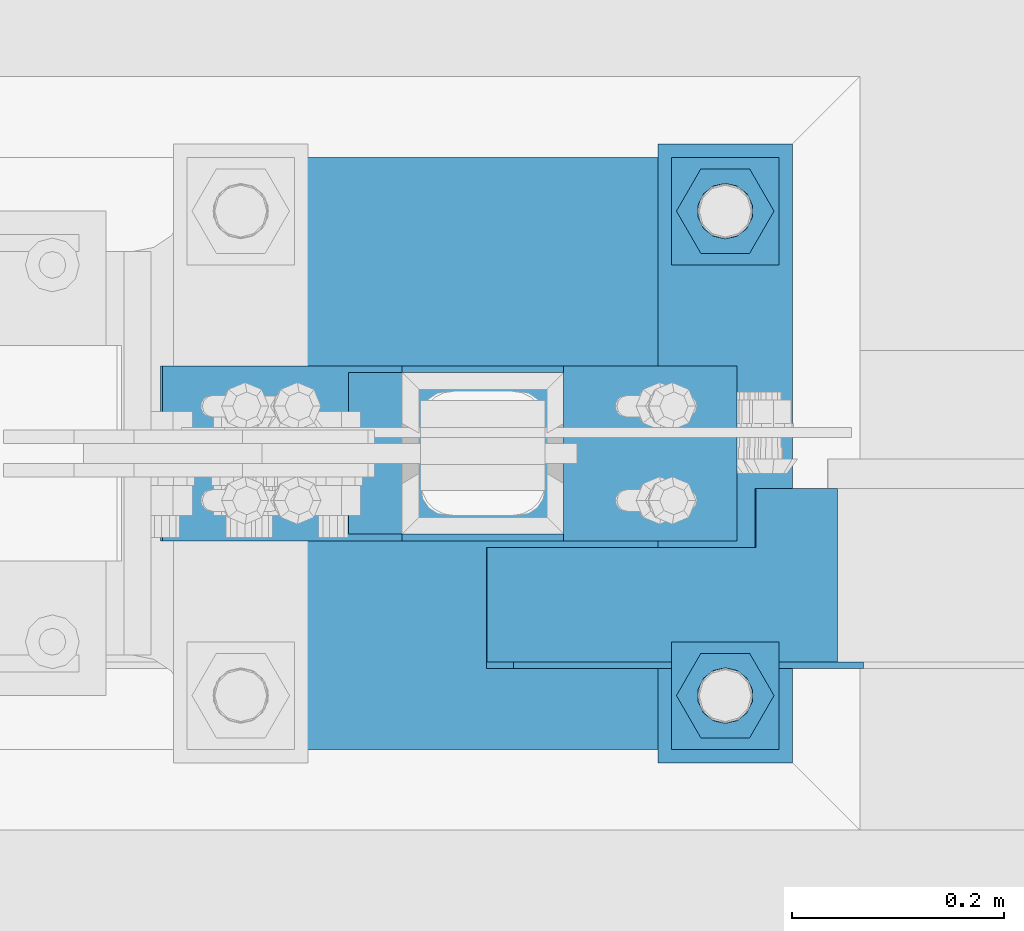
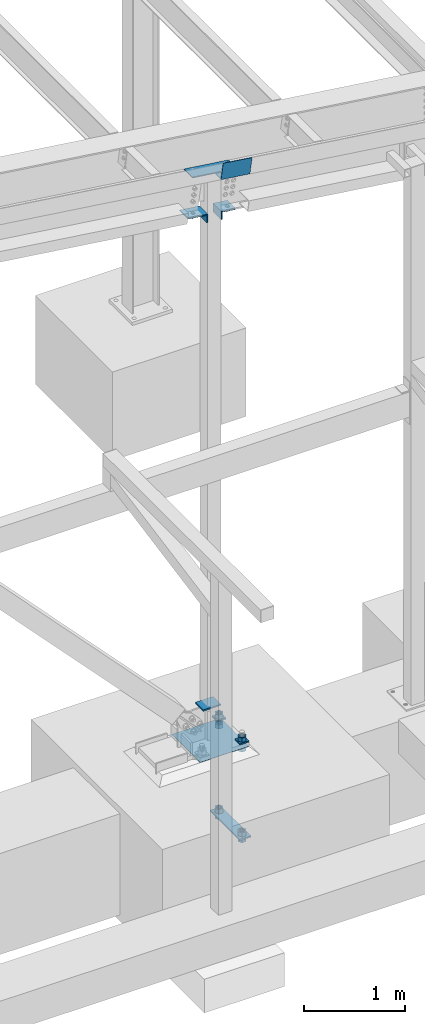
# One storey, part 853 of 1179: 17 beams, 3 elements without a shape of their own.
"""IFC2X3 building model written with IfcOpenShell, lengths in millimetres."""

from ifc_helpers import new_model, si_unit, frame, origin_with_axes, place, context, subcontext, project, spatial, faceted_brep, material, type_object, element, aggregate, save


model = new_model("IFC2X3")

# Units and contexts
model_context = context("Model", 3, precision=1e-05, world=origin_with_axes())
body_context = subcontext(model_context, "Body", "Model", "MODEL_VIEW")
ifc_project = project(units=[si_unit("LENGTHUNIT", "METRE", prefix="MILLI"), si_unit("AREAUNIT", "SQUARE_METRE"), si_unit("VOLUMEUNIT", "CUBIC_METRE"), si_unit("MASSUNIT", "GRAM", prefix="KILO"), si_unit("TIMEUNIT", "SECOND"), si_unit("PLANEANGLEUNIT", "RADIAN"), si_unit("SOLIDANGLEUNIT", "STERADIAN"), si_unit("THERMODYNAMICTEMPERATUREUNIT", "DEGREE_CELSIUS"), si_unit("LUMINOUSINTENSITYUNIT", "LUMEN")], contexts=[model_context])

# Site, building, storey
site_placement = place(None, origin_with_axes())
site = spatial("IfcSite", under=ifc_project, at=site_placement, CompositionType="ELEMENT")
building_placement = place(site_placement, origin_with_axes())
building = spatial("IfcBuilding", under=site, at=building_placement, Name="Undefined", CompositionType="ELEMENT")
storey_placement = place(building_placement, origin_with_axes())
storey = spatial("IfcBuildingStorey", under=building, at=storey_placement, Name="Undefined", CompositionType="ELEMENT", Elevation=0.0)

# Assembly, beam
assembly_1_placement = place(storey_placement, origin_with_axes())
assembly_1 = element("IfcElementAssembly", 1, at=assembly_1_placement, inside=storey, Name="TEMPLATE", AssemblyPlace="NOTDEFINED", PredefinedType="RIGID_FRAME")
ifc_material = material(Name="STEEL/A36")
beam_type_1 = type_object("IfcBeamType", PredefinedType="NOTDEFINED")
beam_1_placement = place(assembly_1_placement, frame((35153.6000061035, 4356.09999389649, -1362.075), z_axis=(-1.0, 0.0, 0.0), x_axis=(0.0, 1.0, 0.0)))
beam_1 = element("IfcBeam", 2, at=beam_1_placement, type_object=beam_type_1, material=ifc_material, Name="SQ WASHER", context=body_context, shape_type="Brep", body=[
    faceted_brep([(0.0, 9.52500000000146, -63.5), (0.0, 9.52500000000146, 63.5), (584.199999999997, 9.52500000000009, 63.5), (584.199999999997, 9.52500000000009, -63.5), (0.0, -9.52500000000146, 63.5), (584.199999999997, -9.52500000000009, 63.5), (0.0, -9.52500000000146, -63.5), (584.199999999997, -9.52500000000009, -63.5)], [[[0, 1, 2, 3]], [[1, 4, 5, 2]], [[4, 6, 7, 5]], [[6, 0, 3, 7]], [[5, 7, 3, 2]], [[6, 4, 1, 0]]]),
])

assembly_2_placement = place(storey_placement, origin_with_axes())
assembly_2 = element("IfcElementAssembly", 3, at=assembly_2_placement, inside=storey, Name="BEAM", AssemblyPlace="NOTDEFINED", PredefinedType="RIGID_FRAME")
beam_type_2 = type_object("IfcBeamType", PredefinedType="NOTDEFINED")
beam_2_placement = place(assembly_2_placement, frame((35118.8262726034, 4448.17500002817, 6769.07814906034), z_axis=(0.99100656965293, 0.0, -0.133813223953134), x_axis=(-0.133813222971046, 0.0, -0.991006569785539)))
beam_2 = element("IfcBeam", 4, at=beam_2_placement, type_object=beam_type_2, material=ifc_material, Name="BENT_PLATE", context=body_context, shape_type="Brep", body=[
    faceted_brep([(190.500000000864, 111.125000986845, 89.1470595671053), (184.150000000862, 111.125000986845, 89.1470595671271), (184.15000000084, 166.687499975929, 89.1470595669234), (190.500000000842, 166.687499975929, 89.1470595669234), (190.500000000628, 111.125000986845, -166.6875000004), (184.150000000625, 111.125000986845, -166.687500000393), (-1.21872290037572e-10, 3.17500000000018, -166.687500000036), (1.20053300634027e-10, 3.17500000000018, 166.687500000036), (184.15000000098, 3.17500000000018, 166.687499999738), (184.150000000571, 3.17500000000018, -166.687500000342), (-1.21872290037572e-10, -3.17500000000018, -166.687500000036), (1.20053300634027e-10, -3.17500000000018, 166.687500000036), (190.500000000573, -3.17500000000018, -166.687500000342), (190.500000000982, -3.17500000000018, 166.687499999724), (190.5000000009, 166.687499975969, 166.687499999643), (184.150000000898, 166.687499975969, 166.687499999651)], [[[0, 1, 2, 3]], [[4, 5, 1, 0]], [[6, 7, 8, 9]], [[10, 11, 7, 6]], [[11, 10, 12, 13]], [[8, 7, 11, 13, 14, 15]], [[15, 14, 3, 2]], [[9, 8, 15, 2, 1, 5]], [[12, 10, 6, 9, 5, 4]], [[14, 13, 12, 4, 0, 3]]]),
])
aggregate(assembly_2, [beam_2])

# Assembly, beams
assembly_3_placement = place(storey_placement, origin_with_axes())
assembly_3 = element("IfcElementAssembly", 5, at=assembly_3_placement, inside=storey, Name="COLUMN", AssemblyPlace="NOTDEFINED", PredefinedType="RIGID_FRAME")
beam_type_3 = type_object("IfcBeamType", PredefinedType="NOTDEFINED")
beam_3_placement = place(assembly_3_placement, frame((35007.55, 4648.2000010376, 6020.17159338622), z_axis=(0.0, -1.0, 0.0), x_axis=(0.0, 0.0, 1.0)))
beam_3 = element("IfcBeam", 6, at=beam_3_placement, type_object=beam_type_3, material=ifc_material, Name="BENT_PLATE", context=body_context, shape_type="Brep", body=[
    faceted_brep([(-7.27595761418343e-12, -6.35000000000218, -82.5500000000002), (-7.27595761418343e-12, -6.35000000000218, 82.5500000000002), (1.09139364212751e-11, 6.35000000000218, 82.5500000000002), (1.09139364212751e-11, 6.35000000000218, -82.5500000000002), (101.6, 6.34999999999854, 82.5500000000002), (101.6, 6.34999999999854, -82.5500000000002), (87.0698965827769, -6.34999999999854, -82.5500000000002), (87.0698965827769, -6.34999999999854, 82.5500000000002), (79.5197174631803, -157.174234805418, 82.5500000000002), (79.5197174631803, -157.174234805418, -82.5500000000002), (66.9339340285887, -155.474806861217, 82.5500000000002), (66.9339340285887, -155.474806861217, -82.5500000000002)], [[[0, 1, 2, 3]], [[3, 2, 4, 5]], [[1, 0, 6, 7]], [[5, 4, 8, 9]], [[4, 2, 1, 7, 10, 8]], [[7, 6, 11, 10]], [[6, 0, 3, 5, 9, 11]], [[10, 11, 9, 8]]]),
])
beam_4_placement = place(assembly_3_placement, frame((34621.591346649, 4648.2000010376, 6166.62160660569), z_axis=(0.0, -1.0, 0.0), x_axis=(0.99100656965293, 0.0, -0.133813223953134)))
beam_4 = element("IfcBeam", 7, at=beam_4_placement, type_object=beam_type_3, material=ifc_material, Name="BENT_PLATE", context=body_context, shape_type="Brep", body=[
    faceted_brep([(-7.27595761418343e-12, -6.35000000000218, -82.5500000000002), (-7.27595761418343e-12, -6.35000000000218, 82.5500000000002), (1.09139364212751e-11, 6.35000000000218, 82.5500000000002), (1.09139364212751e-11, 6.35000000000218, -82.5500000000002), (228.413157209885, 6.35000000041691, 82.5500000000002), (228.413157209885, 6.35000000041691, -82.5500000000002), (217.312754455081, -6.34999999960746, -82.5500000000002), (217.312754455081, -6.34999999960746, 82.5500000000002), (242.008580763424, -94.3362674762175, 82.5500000000002), (242.008580763424, -94.3362674762175, -82.5500000000002), (229.422797328829, -96.0356954204253, 82.5500000000002), (229.422797328829, -96.0356954204253, -82.5500000000002)], [[[0, 1, 2, 3]], [[3, 2, 4, 5]], [[1, 0, 6, 7]], [[5, 4, 8, 9]], [[4, 2, 1, 7, 10, 8]], [[7, 6, 11, 10]], [[6, 0, 3, 5, 9, 11]], [[10, 11, 9, 8]]]),
])
beam_5_placement = place(assembly_3_placement, frame((34673.4487458878, 4648.2000010376, 6643.39523121626), z_axis=(0.0, -1.0, 0.0), x_axis=(0.99100656965293, 0.0, -0.133813223953134)))
beam_5 = element("IfcBeam", 8, at=beam_5_placement, type_object=beam_type_3, material=ifc_material, Name="PLATE", context=body_context, shape_type="Brep", body=[
    faceted_brep([(1.09139364212751e-11, 6.35000000000218, -82.5500000000002), (1.09139364212751e-11, 6.35000000000218, 82.5500000000002), (509.383037032239, 6.34999999986394, 82.5500000000002), (509.383037032239, 6.34999999986394, -82.5500000000002), (-7.27595761418343e-12, -6.35000000000218, 82.5500000000002), (509.383037032225, -6.35000000014043, 82.5500000000002), (-7.27595761418343e-12, -6.35000000000218, -82.5500000000002), (509.383037032225, -6.35000000014043, -82.5500000000002)], [[[0, 1, 2, 3]], [[1, 4, 5, 2]], [[4, 6, 7, 5]], [[6, 0, 3, 7]], [[5, 7, 3, 2]], [[6, 4, 1, 0]]]),
])

# Beam
beam_type_4 = type_object("IfcBeamType", PredefinedType="NOTDEFINED")
beam_6_placement = place(assembly_1_placement, frame((35102.8010061035, 4419.59999389649, -220.662499999998), z_axis=(0.0, 1.0, 0.0), x_axis=(1.0, 0.0, 0.0)))
beam_6 = element("IfcBeam", 9, at=beam_6_placement, type_object=beam_type_4, material=ifc_material, Name="SQ WASHER", context=body_context, shape_type="Brep", body=[
    faceted_brep([(0.0, 7.9375, -50.8000000000002), (0.0, 7.9375, 50.8000000000002), (101.598992919513, 7.9375, 50.8000000000002), (101.598992919513, 7.9375, -50.8000000000002), (0.0, -7.9375, 50.8000000000002), (101.598992919513, -7.9375, 50.8000000000002), (0.0, -7.9375, -50.8000000000002), (101.598992919513, -7.9375, -50.8000000000002)], [[[0, 1, 2, 3]], [[1, 4, 5, 2]], [[4, 6, 7, 5]], [[6, 0, 3, 7]], [[5, 7, 3, 2]], [[6, 4, 1, 0]]]),
])

beam_7_placement = place(assembly_1_placement, frame((35102.8010061035, 4876.79999389648, -220.662499999998), z_axis=(0.0, 1.0, 0.0), x_axis=(1.0, 0.0, 0.0)))
beam_7 = element("IfcBeam", 10, at=beam_7_placement, type_object=beam_type_4, material=ifc_material, Name="SQ WASHER", context=body_context, shape_type="Brep", body=[
    faceted_brep([(0.0, 7.9375, -50.8000000000002), (0.0, 7.9375, 50.8000000000002), (101.598992919513, 7.9375, 50.8000000000002), (101.598992919513, 7.9375, -50.8000000000002), (0.0, -7.9375, 50.8000000000002), (101.598992919513, -7.9375, 50.8000000000002), (0.0, -7.9375, -50.8000000000002), (101.598992919513, -7.9375, -50.8000000000002)], [[[0, 1, 2, 3]], [[1, 4, 5, 2]], [[4, 6, 7, 5]], [[6, 0, 3, 7]], [[5, 7, 3, 2]], [[6, 4, 1, 0]]]),
])

beam_type_5 = type_object("IfcBeamType", PredefinedType="NOTDEFINED")
beam_8_placement = place(assembly_3_placement, frame((34798.0000013588, 4648.2, 169.719733064332), z_axis=(0.0, -1.0, 0.0), x_axis=(1.0, 0.0, 0.0)))
beam_8 = element("IfcBeam", 11, at=beam_8_placement, type_object=beam_type_5, material=ifc_material, Name="PLATE", context=body_context, shape_type="Brep", body=[
    faceted_brep([(0.0, 9.52500000000009, -76.2000000000007), (0.0, 9.52500000000009, 76.2000000000007), (203.200000000004, 9.52500000000001, 76.1999999999998), (203.200000000004, 9.52500000000001, -76.1999999999998), (0.0, -9.52500000000009, 76.2000000000007), (203.200000000004, -9.52500000000001, 76.1999999999998), (0.0, -9.52500000000009, -76.2000000000007), (203.200000000004, -9.52500000000001, -76.1999999999998)], [[[0, 1, 2, 3]], [[1, 4, 5, 2]], [[4, 6, 7, 5]], [[6, 0, 3, 7]], [[5, 7, 3, 2]], [[6, 4, 1, 0]]]),
])

aggregate(assembly_3, [beam_3, beam_4, beam_5, beam_8])

beam_type_6 = type_object("IfcBeamType", Name="2_HEAVY_HEX_NUT", PredefinedType="NOTDEFINED")
beam_9_placement = place(assembly_1_placement, frame((35153.600012207, 4876.8, -279.4), z_axis=(0.0, 1.0, 0.0), x_axis=(0.0, 0.0, -1.0)))
beam_9 = element("IfcBeam", 12, at=beam_9_placement, type_object=beam_type_6, material=ifc_material, Name="NUT", ObjectType="2_HEAVY_HEX_NUT", context=body_context, shape_type="Brep", body=[
    faceted_brep([(0.0, -46.0369987487793, 9.09494701772928e-13), (0.0, -23.0184993743896, -39.869213104248), (50.7999999999993, -23.0184993743896, -39.869213104248), (50.7999999999993, -46.0369987487793, 9.09494701772928e-13), (0.0, 23.0184993743896, -39.869213104248), (50.7999999999993, 23.0184993743896, -39.869213104248), (0.0, 46.0369987487793, -9.09494701772928e-13), (50.7999999999993, 46.0369987487793, -9.09494701772928e-13), (0.0, 23.0184993743896, 39.869213104248), (50.7999999999993, 23.0184993743896, 39.869213104248), (0.0, -23.0184993743896, 39.869213104248), (50.7999999999993, -23.0184993743896, 39.869213104248), (0.0, 0.0, 26.1940002441406), (0.0, 11.3650617044477, 23.5999013092769), (50.7999999999993, 11.3650617044477, 23.5999013092769), (50.7999999999993, 0.0, 26.1940002441406), (0.0, 20.4791109456419, 16.3316083006703), (50.7999999999993, 20.4791109456419, 16.3316083006703), (0.0, 25.5370200498364, 5.82867859874477), (50.7999999999993, 25.5370200498364, 5.82867859874477), (0.0, 25.5370200498364, -5.82867859874477), (50.7999999999993, 25.5370200498364, -5.82867859874477), (0.0, 20.4791109456419, -16.3316083006703), (50.7999999999993, 20.4791109456419, -16.3316083006703), (0.0, 11.365061704455, -23.5999013092769), (50.7999999999993, 11.365061704455, -23.5999013092769), (0.0, 0.0, -26.1940002441406), (50.7999999999993, 0.0, -26.1940002441406), (0.0, -11.3650617044477, -23.5999013092769), (50.7999999999993, -11.3650617044477, -23.5999013092769), (0.0, -20.4791109456419, -16.3316083006703), (50.7999999999993, -20.4791109456419, -16.3316083006703), (0.0, -25.5370200498364, -5.82867859874477), (50.7999999999993, -25.5370200498364, -5.82867859874477), (0.0, -25.5370200498364, 5.82867859874477), (50.7999999999993, -25.5370200498364, 5.82867859874477), (0.0, -20.4791109456419, 16.3316083006703), (50.7999999999993, -20.4791109456419, 16.3316083006703), (0.0, -11.365061704455, 23.5999013092769), (50.7999999999993, -11.365061704455, 23.5999013092769)], [[[0, 1, 2, 3]], [[1, 4, 5, 2]], [[4, 6, 7, 5]], [[6, 8, 9, 7]], [[8, 10, 11, 9]], [[10, 0, 3, 11]], [[12, 13, 14, 15]], [[13, 16, 17, 14]], [[16, 18, 19, 17]], [[18, 20, 21, 19]], [[20, 22, 23, 21]], [[22, 24, 25, 23]], [[24, 26, 27, 25]], [[26, 28, 29, 27]], [[28, 30, 31, 29]], [[30, 32, 33, 31]], [[32, 34, 35, 33]], [[34, 36, 37, 35]], [[36, 38, 39, 37]], [[38, 12, 15, 39]], [[5, 7, 9, 11, 3, 2], [17, 19, 21, 23, 25, 27, 29, 31, 33, 35, 37, 39, 15, 14]], [[10, 8, 6, 4, 1, 0], [38, 36, 34, 32, 30, 28, 26, 24, 22, 20, 18, 16, 13, 12]]]),
])

beam_10_placement = place(assembly_1_placement, frame((35153.600012207, 4419.6, -279.4), z_axis=(0.0, 1.0, 0.0), x_axis=(0.0, 0.0, -1.0)))
beam_10 = element("IfcBeam", 13, at=beam_10_placement, type_object=beam_type_6, material=ifc_material, Name="NUT", ObjectType="2_HEAVY_HEX_NUT", context=body_context, shape_type="Brep", body=[
    faceted_brep([(0.0, -46.0369987487793, 9.09494701772928e-13), (0.0, -23.0184993743896, -39.869213104248), (50.7999999999993, -23.0184993743896, -39.869213104248), (50.7999999999993, -46.0369987487793, 9.09494701772928e-13), (0.0, 23.0184993743896, -39.869213104248), (50.7999999999993, 23.0184993743896, -39.869213104248), (0.0, 46.0369987487793, -9.09494701772928e-13), (50.7999999999993, 46.0369987487793, -9.09494701772928e-13), (0.0, 23.0184993743896, 39.869213104248), (50.7999999999993, 23.0184993743896, 39.869213104248), (0.0, -23.0184993743896, 39.869213104248), (50.7999999999993, -23.0184993743896, 39.869213104248), (0.0, 0.0, 26.1940002441406), (0.0, 11.3650617044477, 23.5999013092769), (50.7999999999993, 11.3650617044477, 23.5999013092769), (50.7999999999993, 0.0, 26.1940002441406), (0.0, 20.4791109456419, 16.3316083006703), (50.7999999999993, 20.4791109456419, 16.3316083006703), (0.0, 25.5370200498364, 5.82867859874477), (50.7999999999993, 25.5370200498364, 5.82867859874477), (0.0, 25.5370200498364, -5.82867859874477), (50.7999999999993, 25.5370200498364, -5.82867859874477), (0.0, 20.4791109456419, -16.3316083006703), (50.7999999999993, 20.4791109456419, -16.3316083006703), (0.0, 11.365061704455, -23.5999013092769), (50.7999999999993, 11.365061704455, -23.5999013092769), (0.0, 0.0, -26.1940002441406), (50.7999999999993, 0.0, -26.1940002441406), (0.0, -11.3650617044477, -23.5999013092769), (50.7999999999993, -11.3650617044477, -23.5999013092769), (0.0, -20.4791109456419, -16.3316083006703), (50.7999999999993, -20.4791109456419, -16.3316083006703), (0.0, -25.5370200498364, -5.82867859874477), (50.7999999999993, -25.5370200498364, -5.82867859874477), (0.0, -25.5370200498364, 5.82867859874477), (50.7999999999993, -25.5370200498364, 5.82867859874477), (0.0, -20.4791109456419, 16.3316083006703), (50.7999999999993, -20.4791109456419, 16.3316083006703), (0.0, -11.365061704455, 23.5999013092769), (50.7999999999993, -11.365061704455, 23.5999013092769)], [[[0, 1, 2, 3]], [[1, 4, 5, 2]], [[4, 6, 7, 5]], [[6, 8, 9, 7]], [[8, 10, 11, 9]], [[10, 0, 3, 11]], [[12, 13, 14, 15]], [[13, 16, 17, 14]], [[16, 18, 19, 17]], [[18, 20, 21, 19]], [[20, 22, 23, 21]], [[22, 24, 25, 23]], [[24, 26, 27, 25]], [[26, 28, 29, 27]], [[28, 30, 31, 29]], [[30, 32, 33, 31]], [[32, 34, 35, 33]], [[34, 36, 37, 35]], [[36, 38, 39, 37]], [[38, 12, 15, 39]], [[5, 7, 9, 11, 3, 2], [17, 19, 21, 23, 25, 27, 29, 31, 33, 35, 37, 39, 15, 14]], [[10, 8, 6, 4, 1, 0], [38, 36, 34, 32, 30, 28, 26, 24, 22, 20, 18, 16, 13, 12]]]),
])

beam_11_placement = place(assembly_1_placement, frame((35153.6, 4876.8, -1301.75), z_axis=(0.0, 1.0, 0.0), x_axis=(0.0, 0.0, -1.0)))
beam_11 = element("IfcBeam", 14, at=beam_11_placement, type_object=beam_type_6, material=ifc_material, Name="NUT", ObjectType="2_HEAVY_HEX_NUT", context=body_context, shape_type="Brep", body=[
    faceted_brep([(0.0, -46.0369987487793, 9.09494701772928e-13), (0.0, -23.0184993743896, -39.869213104248), (50.7999999999993, -23.0184993743896, -39.869213104248), (50.7999999999993, -46.0369987487793, 9.09494701772928e-13), (0.0, 23.0184993743896, -39.869213104248), (50.7999999999993, 23.0184993743896, -39.869213104248), (0.0, 46.0369987487793, -9.09494701772928e-13), (50.7999999999993, 46.0369987487793, -9.09494701772928e-13), (0.0, 23.0184993743896, 39.869213104248), (50.7999999999993, 23.0184993743896, 39.869213104248), (0.0, -23.0184993743896, 39.869213104248), (50.7999999999993, -23.0184993743896, 39.869213104248), (0.0, 0.0, 26.1940002441406), (0.0, 11.3650617044477, 23.5999013092769), (50.7999999999993, 11.3650617044477, 23.5999013092769), (50.7999999999993, 0.0, 26.1940002441406), (0.0, 20.4791109456419, 16.3316083006703), (50.7999999999993, 20.4791109456419, 16.3316083006703), (0.0, 25.5370200498364, 5.82867859874477), (50.7999999999993, 25.5370200498364, 5.82867859874477), (0.0, 25.5370200498364, -5.82867859874477), (50.7999999999993, 25.5370200498364, -5.82867859874477), (0.0, 20.4791109456419, -16.3316083006703), (50.7999999999993, 20.4791109456419, -16.3316083006703), (0.0, 11.365061704455, -23.5999013092769), (50.7999999999993, 11.365061704455, -23.5999013092769), (0.0, 0.0, -26.1940002441406), (50.7999999999993, 0.0, -26.1940002441406), (0.0, -11.3650617044477, -23.5999013092769), (50.7999999999993, -11.3650617044477, -23.5999013092769), (0.0, -20.4791109456419, -16.3316083006703), (50.7999999999993, -20.4791109456419, -16.3316083006703), (0.0, -25.5370200498364, -5.82867859874477), (50.7999999999993, -25.5370200498364, -5.82867859874477), (0.0, -25.5370200498364, 5.82867859874477), (50.7999999999993, -25.5370200498364, 5.82867859874477), (0.0, -20.4791109456419, 16.3316083006703), (50.7999999999993, -20.4791109456419, 16.3316083006703), (0.0, -11.365061704455, 23.5999013092769), (50.7999999999993, -11.365061704455, 23.5999013092769)], [[[0, 1, 2, 3]], [[1, 4, 5, 2]], [[4, 6, 7, 5]], [[6, 8, 9, 7]], [[8, 10, 11, 9]], [[10, 0, 3, 11]], [[12, 13, 14, 15]], [[13, 16, 17, 14]], [[16, 18, 19, 17]], [[18, 20, 21, 19]], [[20, 22, 23, 21]], [[22, 24, 25, 23]], [[24, 26, 27, 25]], [[26, 28, 29, 27]], [[28, 30, 31, 29]], [[30, 32, 33, 31]], [[32, 34, 35, 33]], [[34, 36, 37, 35]], [[36, 38, 39, 37]], [[38, 12, 15, 39]], [[5, 7, 9, 11, 3, 2], [17, 19, 21, 23, 25, 27, 29, 31, 33, 35, 37, 39, 15, 14]], [[10, 8, 6, 4, 1, 0], [38, 36, 34, 32, 30, 28, 26, 24, 22, 20, 18, 16, 13, 12]]]),
])

beam_12_placement = place(assembly_1_placement, frame((35153.6, 4876.8, -1371.59999923706), z_axis=(0.0, 1.0, 0.0), x_axis=(0.0, 0.0, -1.0)))
beam_12 = element("IfcBeam", 15, at=beam_12_placement, type_object=beam_type_6, material=ifc_material, Name="NUT", ObjectType="2_HEAVY_HEX_NUT", context=body_context, shape_type="Brep", body=[
    faceted_brep([(0.0, -46.0369987487793, 9.09494701772928e-13), (0.0, -23.0184993743896, -39.869213104248), (50.7999999999993, -23.0184993743896, -39.869213104248), (50.7999999999993, -46.0369987487793, 9.09494701772928e-13), (0.0, 23.0184993743896, -39.869213104248), (50.7999999999993, 23.0184993743896, -39.869213104248), (0.0, 46.0369987487793, -9.09494701772928e-13), (50.7999999999993, 46.0369987487793, -9.09494701772928e-13), (0.0, 23.0184993743896, 39.869213104248), (50.7999999999993, 23.0184993743896, 39.869213104248), (0.0, -23.0184993743896, 39.869213104248), (50.7999999999993, -23.0184993743896, 39.869213104248), (0.0, 0.0, 26.1940002441406), (0.0, 11.3650617044477, 23.5999013092769), (50.7999999999993, 11.3650617044477, 23.5999013092769), (50.7999999999993, 0.0, 26.1940002441406), (0.0, 20.4791109456419, 16.3316083006703), (50.7999999999993, 20.4791109456419, 16.3316083006703), (0.0, 25.5370200498364, 5.82867859874477), (50.7999999999993, 25.5370200498364, 5.82867859874477), (0.0, 25.5370200498364, -5.82867859874477), (50.7999999999993, 25.5370200498364, -5.82867859874477), (0.0, 20.4791109456419, -16.3316083006703), (50.7999999999993, 20.4791109456419, -16.3316083006703), (0.0, 11.365061704455, -23.5999013092769), (50.7999999999993, 11.365061704455, -23.5999013092769), (0.0, 0.0, -26.1940002441406), (50.7999999999993, 0.0, -26.1940002441406), (0.0, -11.3650617044477, -23.5999013092769), (50.7999999999993, -11.3650617044477, -23.5999013092769), (0.0, -20.4791109456419, -16.3316083006703), (50.7999999999993, -20.4791109456419, -16.3316083006703), (0.0, -25.5370200498364, -5.82867859874477), (50.7999999999993, -25.5370200498364, -5.82867859874477), (0.0, -25.5370200498364, 5.82867859874477), (50.7999999999993, -25.5370200498364, 5.82867859874477), (0.0, -20.4791109456419, 16.3316083006703), (50.7999999999993, -20.4791109456419, 16.3316083006703), (0.0, -11.365061704455, 23.5999013092769), (50.7999999999993, -11.365061704455, 23.5999013092769)], [[[0, 1, 2, 3]], [[1, 4, 5, 2]], [[4, 6, 7, 5]], [[6, 8, 9, 7]], [[8, 10, 11, 9]], [[10, 0, 3, 11]], [[12, 13, 14, 15]], [[13, 16, 17, 14]], [[16, 18, 19, 17]], [[18, 20, 21, 19]], [[20, 22, 23, 21]], [[22, 24, 25, 23]], [[24, 26, 27, 25]], [[26, 28, 29, 27]], [[28, 30, 31, 29]], [[30, 32, 33, 31]], [[32, 34, 35, 33]], [[34, 36, 37, 35]], [[36, 38, 39, 37]], [[38, 12, 15, 39]], [[5, 7, 9, 11, 3, 2], [17, 19, 21, 23, 25, 27, 29, 31, 33, 35, 37, 39, 15, 14]], [[10, 8, 6, 4, 1, 0], [38, 36, 34, 32, 30, 28, 26, 24, 22, 20, 18, 16, 13, 12]]]),
])

beam_13_placement = place(assembly_1_placement, frame((35153.6, 4419.6, -1301.75), z_axis=(0.0, 1.0, 0.0), x_axis=(0.0, 0.0, -1.0)))
beam_13 = element("IfcBeam", 16, at=beam_13_placement, type_object=beam_type_6, material=ifc_material, Name="NUT", ObjectType="2_HEAVY_HEX_NUT", context=body_context, shape_type="Brep", body=[
    faceted_brep([(0.0, -46.0369987487793, 9.09494701772928e-13), (0.0, -23.0184993743896, -39.869213104248), (50.7999999999993, -23.0184993743896, -39.869213104248), (50.7999999999993, -46.0369987487793, 9.09494701772928e-13), (0.0, 23.0184993743896, -39.869213104248), (50.7999999999993, 23.0184993743896, -39.869213104248), (0.0, 46.0369987487793, -9.09494701772928e-13), (50.7999999999993, 46.0369987487793, -9.09494701772928e-13), (0.0, 23.0184993743896, 39.869213104248), (50.7999999999993, 23.0184993743896, 39.869213104248), (0.0, -23.0184993743896, 39.869213104248), (50.7999999999993, -23.0184993743896, 39.869213104248), (0.0, 0.0, 26.1940002441406), (0.0, 11.3650617044477, 23.5999013092769), (50.7999999999993, 11.3650617044477, 23.5999013092769), (50.7999999999993, 0.0, 26.1940002441406), (0.0, 20.4791109456419, 16.3316083006703), (50.7999999999993, 20.4791109456419, 16.3316083006703), (0.0, 25.5370200498364, 5.82867859874477), (50.7999999999993, 25.5370200498364, 5.82867859874477), (0.0, 25.5370200498364, -5.82867859874477), (50.7999999999993, 25.5370200498364, -5.82867859874477), (0.0, 20.4791109456419, -16.3316083006703), (50.7999999999993, 20.4791109456419, -16.3316083006703), (0.0, 11.365061704455, -23.5999013092769), (50.7999999999993, 11.365061704455, -23.5999013092769), (0.0, 0.0, -26.1940002441406), (50.7999999999993, 0.0, -26.1940002441406), (0.0, -11.3650617044477, -23.5999013092769), (50.7999999999993, -11.3650617044477, -23.5999013092769), (0.0, -20.4791109456419, -16.3316083006703), (50.7999999999993, -20.4791109456419, -16.3316083006703), (0.0, -25.5370200498364, -5.82867859874477), (50.7999999999993, -25.5370200498364, -5.82867859874477), (0.0, -25.5370200498364, 5.82867859874477), (50.7999999999993, -25.5370200498364, 5.82867859874477), (0.0, -20.4791109456419, 16.3316083006703), (50.7999999999993, -20.4791109456419, 16.3316083006703), (0.0, -11.365061704455, 23.5999013092769), (50.7999999999993, -11.365061704455, 23.5999013092769)], [[[0, 1, 2, 3]], [[1, 4, 5, 2]], [[4, 6, 7, 5]], [[6, 8, 9, 7]], [[8, 10, 11, 9]], [[10, 0, 3, 11]], [[12, 13, 14, 15]], [[13, 16, 17, 14]], [[16, 18, 19, 17]], [[18, 20, 21, 19]], [[20, 22, 23, 21]], [[22, 24, 25, 23]], [[24, 26, 27, 25]], [[26, 28, 29, 27]], [[28, 30, 31, 29]], [[30, 32, 33, 31]], [[32, 34, 35, 33]], [[34, 36, 37, 35]], [[36, 38, 39, 37]], [[38, 12, 15, 39]], [[5, 7, 9, 11, 3, 2], [17, 19, 21, 23, 25, 27, 29, 31, 33, 35, 37, 39, 15, 14]], [[10, 8, 6, 4, 1, 0], [38, 36, 34, 32, 30, 28, 26, 24, 22, 20, 18, 16, 13, 12]]]),
])

beam_14_placement = place(assembly_1_placement, frame((35153.6, 4419.59998779297, -1371.6), z_axis=(0.0, 1.0, 0.0), x_axis=(0.0, 0.0, -1.0)))
beam_14 = element("IfcBeam", 17, at=beam_14_placement, type_object=beam_type_6, material=ifc_material, Name="NUT", ObjectType="2_HEAVY_HEX_NUT", context=body_context, shape_type="Brep", body=[
    faceted_brep([(0.0, -46.0369987487793, 9.09494701772928e-13), (0.0, -23.0184993743896, -39.869213104248), (50.7999999999993, -23.0184993743896, -39.869213104248), (50.7999999999993, -46.0369987487793, 9.09494701772928e-13), (0.0, 23.0184993743896, -39.869213104248), (50.7999999999993, 23.0184993743896, -39.869213104248), (0.0, 46.0369987487793, -9.09494701772928e-13), (50.7999999999993, 46.0369987487793, -9.09494701772928e-13), (0.0, 23.0184993743896, 39.869213104248), (50.7999999999993, 23.0184993743896, 39.869213104248), (0.0, -23.0184993743896, 39.869213104248), (50.7999999999993, -23.0184993743896, 39.869213104248), (0.0, 0.0, 26.1940002441406), (0.0, 11.3650617044477, 23.5999013092769), (50.7999999999993, 11.3650617044477, 23.5999013092769), (50.7999999999993, 0.0, 26.1940002441406), (0.0, 20.4791109456419, 16.3316083006703), (50.7999999999993, 20.4791109456419, 16.3316083006703), (0.0, 25.5370200498364, 5.82867859874477), (50.7999999999993, 25.5370200498364, 5.82867859874477), (0.0, 25.5370200498364, -5.82867859874477), (50.7999999999993, 25.5370200498364, -5.82867859874477), (0.0, 20.4791109456419, -16.3316083006703), (50.7999999999993, 20.4791109456419, -16.3316083006703), (0.0, 11.365061704455, -23.5999013092769), (50.7999999999993, 11.365061704455, -23.5999013092769), (0.0, 0.0, -26.1940002441406), (50.7999999999993, 0.0, -26.1940002441406), (0.0, -11.3650617044477, -23.5999013092769), (50.7999999999993, -11.3650617044477, -23.5999013092769), (0.0, -20.4791109456419, -16.3316083006703), (50.7999999999993, -20.4791109456419, -16.3316083006703), (0.0, -25.5370200498364, -5.82867859874477), (50.7999999999993, -25.5370200498364, -5.82867859874477), (0.0, -25.5370200498364, 5.82867859874477), (50.7999999999993, -25.5370200498364, 5.82867859874477), (0.0, -20.4791109456419, 16.3316083006703), (50.7999999999993, -20.4791109456419, 16.3316083006703), (0.0, -11.365061704455, 23.5999013092769), (50.7999999999993, -11.365061704455, 23.5999013092769)], [[[0, 1, 2, 3]], [[1, 4, 5, 2]], [[4, 6, 7, 5]], [[6, 8, 9, 7]], [[8, 10, 11, 9]], [[10, 0, 3, 11]], [[12, 13, 14, 15]], [[13, 16, 17, 14]], [[16, 18, 19, 17]], [[18, 20, 21, 19]], [[20, 22, 23, 21]], [[22, 24, 25, 23]], [[24, 26, 27, 25]], [[26, 28, 29, 27]], [[28, 30, 31, 29]], [[30, 32, 33, 31]], [[32, 34, 35, 33]], [[34, 36, 37, 35]], [[36, 38, 39, 37]], [[38, 12, 15, 39]], [[5, 7, 9, 11, 3, 2], [17, 19, 21, 23, 25, 27, 29, 31, 33, 35, 37, 39, 15, 14]], [[10, 8, 6, 4, 1, 0], [38, 36, 34, 32, 30, 28, 26, 24, 22, 20, 18, 16, 13, 12]]]),
])

beam_15_placement = place(assembly_1_placement, frame((35153.6, 4876.8, -161.924999999999), z_axis=(0.0, 1.0, 0.0), x_axis=(0.0, 0.0, -1.0)))
beam_15 = element("IfcBeam", 18, at=beam_15_placement, type_object=beam_type_6, material=ifc_material, Name="NUT", ObjectType="2_HEAVY_HEX_NUT", context=body_context, shape_type="Brep", body=[
    faceted_brep([(0.0, -46.0369987487793, 9.09494701772928e-13), (0.0, -23.0184993743896, -39.869213104248), (50.7999999999993, -23.0184993743896, -39.869213104248), (50.7999999999993, -46.0369987487793, 9.09494701772928e-13), (0.0, 23.0184993743896, -39.869213104248), (50.7999999999993, 23.0184993743896, -39.869213104248), (0.0, 46.0369987487793, -9.09494701772928e-13), (50.7999999999993, 46.0369987487793, -9.09494701772928e-13), (0.0, 23.0184993743896, 39.869213104248), (50.7999999999993, 23.0184993743896, 39.869213104248), (0.0, -23.0184993743896, 39.869213104248), (50.7999999999993, -23.0184993743896, 39.869213104248), (0.0, 0.0, 26.1940002441406), (0.0, 11.3650617044477, 23.5999013092769), (50.7999999999993, 11.3650617044477, 23.5999013092769), (50.7999999999993, 0.0, 26.1940002441406), (0.0, 20.4791109456419, 16.3316083006703), (50.7999999999993, 20.4791109456419, 16.3316083006703), (0.0, 25.5370200498364, 5.82867859874477), (50.7999999999993, 25.5370200498364, 5.82867859874477), (0.0, 25.5370200498364, -5.82867859874477), (50.7999999999993, 25.5370200498364, -5.82867859874477), (0.0, 20.4791109456419, -16.3316083006703), (50.7999999999993, 20.4791109456419, -16.3316083006703), (0.0, 11.365061704455, -23.5999013092769), (50.7999999999993, 11.365061704455, -23.5999013092769), (0.0, 0.0, -26.1940002441406), (50.7999999999993, 0.0, -26.1940002441406), (0.0, -11.3650617044477, -23.5999013092769), (50.7999999999993, -11.3650617044477, -23.5999013092769), (0.0, -20.4791109456419, -16.3316083006703), (50.7999999999993, -20.4791109456419, -16.3316083006703), (0.0, -25.5370200498364, -5.82867859874477), (50.7999999999993, -25.5370200498364, -5.82867859874477), (0.0, -25.5370200498364, 5.82867859874477), (50.7999999999993, -25.5370200498364, 5.82867859874477), (0.0, -20.4791109456419, 16.3316083006703), (50.7999999999993, -20.4791109456419, 16.3316083006703), (0.0, -11.365061704455, 23.5999013092769), (50.7999999999993, -11.365061704455, 23.5999013092769)], [[[0, 1, 2, 3]], [[1, 4, 5, 2]], [[4, 6, 7, 5]], [[6, 8, 9, 7]], [[8, 10, 11, 9]], [[10, 0, 3, 11]], [[12, 13, 14, 15]], [[13, 16, 17, 14]], [[16, 18, 19, 17]], [[18, 20, 21, 19]], [[20, 22, 23, 21]], [[22, 24, 25, 23]], [[24, 26, 27, 25]], [[26, 28, 29, 27]], [[28, 30, 31, 29]], [[30, 32, 33, 31]], [[32, 34, 35, 33]], [[34, 36, 37, 35]], [[36, 38, 39, 37]], [[38, 12, 15, 39]], [[5, 7, 9, 11, 3, 2], [17, 19, 21, 23, 25, 27, 29, 31, 33, 35, 37, 39, 15, 14]], [[10, 8, 6, 4, 1, 0], [38, 36, 34, 32, 30, 28, 26, 24, 22, 20, 18, 16, 13, 12]]]),
])

beam_16_placement = place(assembly_1_placement, frame((35153.6, 4419.6, -161.924999999999), z_axis=(0.0, 1.0, 0.0), x_axis=(0.0, 0.0, -1.0)))
beam_16 = element("IfcBeam", 19, at=beam_16_placement, type_object=beam_type_6, material=ifc_material, Name="NUT", ObjectType="2_HEAVY_HEX_NUT", context=body_context, shape_type="Brep", body=[
    faceted_brep([(0.0, -46.0369987487793, 9.09494701772928e-13), (0.0, -23.0184993743896, -39.869213104248), (50.7999999999993, -23.0184993743896, -39.869213104248), (50.7999999999993, -46.0369987487793, 9.09494701772928e-13), (0.0, 23.0184993743896, -39.869213104248), (50.7999999999993, 23.0184993743896, -39.869213104248), (0.0, 46.0369987487793, -9.09494701772928e-13), (50.7999999999993, 46.0369987487793, -9.09494701772928e-13), (0.0, 23.0184993743896, 39.869213104248), (50.7999999999993, 23.0184993743896, 39.869213104248), (0.0, -23.0184993743896, 39.869213104248), (50.7999999999993, -23.0184993743896, 39.869213104248), (0.0, 0.0, 26.1940002441406), (0.0, 11.3650617044477, 23.5999013092769), (50.7999999999993, 11.3650617044477, 23.5999013092769), (50.7999999999993, 0.0, 26.1940002441406), (0.0, 20.4791109456419, 16.3316083006703), (50.7999999999993, 20.4791109456419, 16.3316083006703), (0.0, 25.5370200498364, 5.82867859874477), (50.7999999999993, 25.5370200498364, 5.82867859874477), (0.0, 25.5370200498364, -5.82867859874477), (50.7999999999993, 25.5370200498364, -5.82867859874477), (0.0, 20.4791109456419, -16.3316083006703), (50.7999999999993, 20.4791109456419, -16.3316083006703), (0.0, 11.365061704455, -23.5999013092769), (50.7999999999993, 11.365061704455, -23.5999013092769), (0.0, 0.0, -26.1940002441406), (50.7999999999993, 0.0, -26.1940002441406), (0.0, -11.3650617044477, -23.5999013092769), (50.7999999999993, -11.3650617044477, -23.5999013092769), (0.0, -20.4791109456419, -16.3316083006703), (50.7999999999993, -20.4791109456419, -16.3316083006703), (0.0, -25.5370200498364, -5.82867859874477), (50.7999999999993, -25.5370200498364, -5.82867859874477), (0.0, -25.5370200498364, 5.82867859874477), (50.7999999999993, -25.5370200498364, 5.82867859874477), (0.0, -20.4791109456419, 16.3316083006703), (50.7999999999993, -20.4791109456419, 16.3316083006703), (0.0, -11.365061704455, 23.5999013092769), (50.7999999999993, -11.365061704455, 23.5999013092769)], [[[0, 1, 2, 3]], [[1, 4, 5, 2]], [[4, 6, 7, 5]], [[6, 8, 9, 7]], [[8, 10, 11, 9]], [[10, 0, 3, 11]], [[12, 13, 14, 15]], [[13, 16, 17, 14]], [[16, 18, 19, 17]], [[18, 20, 21, 19]], [[20, 22, 23, 21]], [[22, 24, 25, 23]], [[24, 26, 27, 25]], [[26, 28, 29, 27]], [[28, 30, 31, 29]], [[30, 32, 33, 31]], [[32, 34, 35, 33]], [[34, 36, 37, 35]], [[36, 38, 39, 37]], [[38, 12, 15, 39]], [[5, 7, 9, 11, 3, 2], [17, 19, 21, 23, 25, 27, 29, 31, 33, 35, 37, 39, 15, 14]], [[10, 8, 6, 4, 1, 0], [38, 36, 34, 32, 30, 28, 26, 24, 22, 20, 18, 16, 13, 12]]]),
])

beam_type_7 = type_object("IfcBeamType", PredefinedType="NOTDEFINED")
beam_17_placement = place(assembly_1_placement, frame((35204.39949646, 4648.2, -277.812499999999), z_axis=(0.0, -1.0, 0.0), x_axis=(-1.0, 0.0, 0.0)))
beam_17 = element("IfcBeam", 20, at=beam_17_placement, type_object=beam_type_7, material=ifc_material, Name="TEMPLATE", context=body_context, shape_type="Brep", body=[
    faceted_brep([(0.0, 1.58749999999998, -279.4), (0.0, 1.58749999999998, 279.4), (558.798992919728, 1.58749999999998, 279.4), (558.798992919728, 1.58749999999998, -279.4), (0.0, -1.58749999999998, 279.4), (558.798992919728, -1.58749999999998, 279.4), (0.0, -1.58749999999998, -279.4), (558.798992919728, -1.58749999999998, -279.4)], [[[0, 1, 2, 3]], [[1, 4, 5, 2]], [[4, 6, 7, 5]], [[6, 0, 3, 7]], [[5, 7, 3, 2]], [[6, 4, 1, 0]]]),
])

aggregate(assembly_1, [beam_9, beam_10, beam_11, beam_12, beam_6, beam_13, beam_14, beam_7, beam_15, beam_16, beam_1, beam_17])

save(model, "model.ifc")
